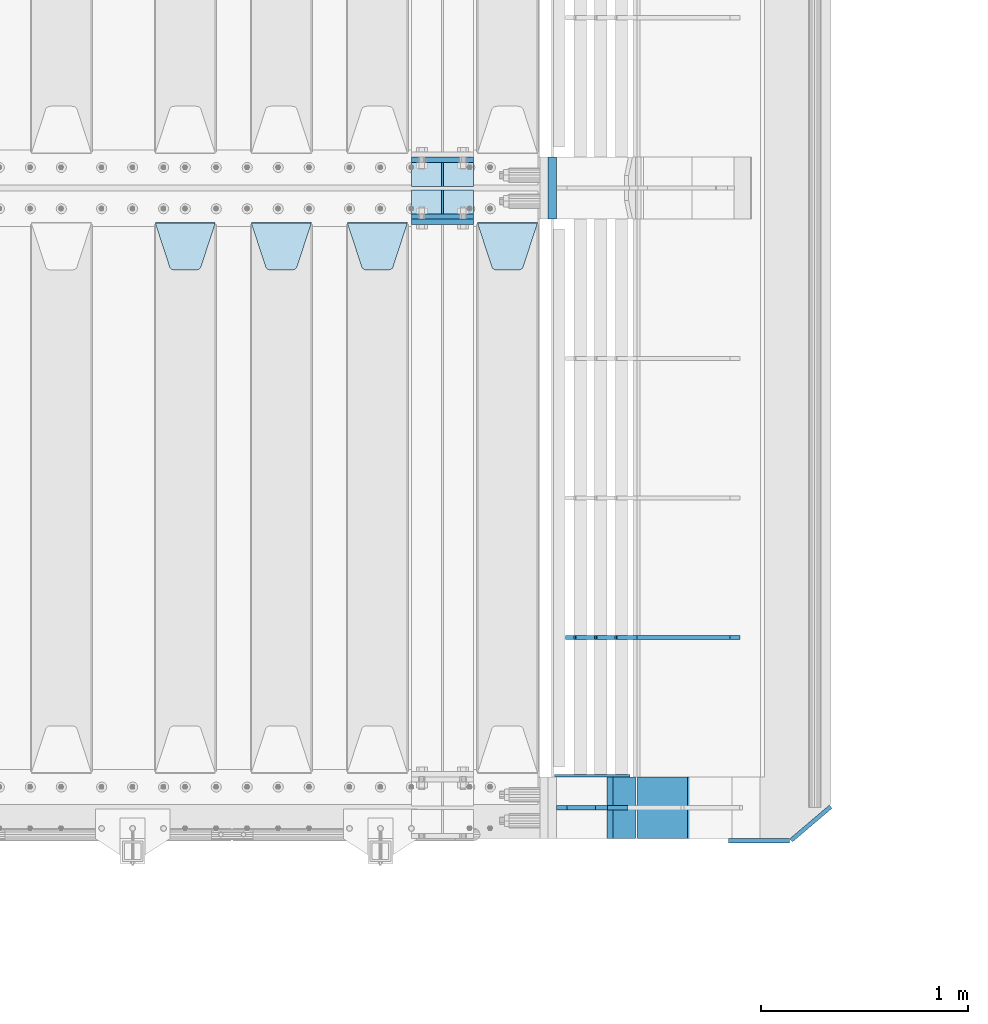
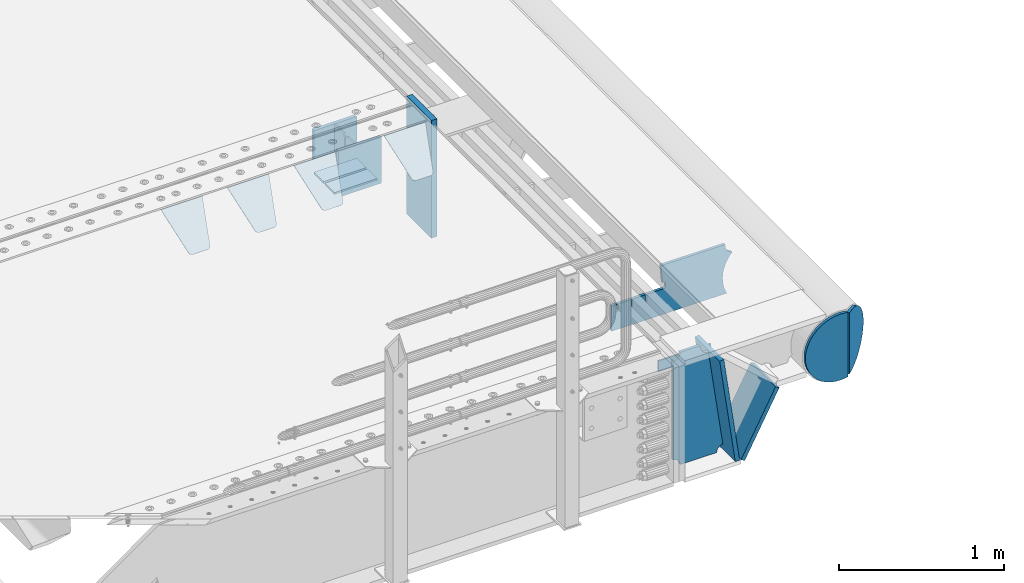
# One storey, part 235 of 257: 19 plates.
"""IFC2X3 building model written with IfcOpenShell, lengths in millimetres."""

from ifc_helpers import new_model, si_unit, frame, origin_with_axes, place, context, subcontext, project, spatial, faceted_brep, material, type_object, element, save


model = new_model("IFC2X3")

# Units and contexts
model_context = context("Model", 3, precision=1e-05, world=origin_with_axes())
body_context = subcontext(model_context, "Body", "Model", "MODEL_VIEW")
ifc_project = project(units=[si_unit("LENGTHUNIT", "METRE", prefix="MILLI"), si_unit("AREAUNIT", "SQUARE_METRE"), si_unit("VOLUMEUNIT", "CUBIC_METRE"), si_unit("MASSUNIT", "GRAM", prefix="KILO"), si_unit("TIMEUNIT", "SECOND"), si_unit("PLANEANGLEUNIT", "RADIAN"), si_unit("SOLIDANGLEUNIT", "STERADIAN"), si_unit("THERMODYNAMICTEMPERATUREUNIT", "DEGREE_CELSIUS"), si_unit("LUMINOUSINTENSITYUNIT", "LUMEN")], contexts=[model_context])

# Site, building, storey
site_placement = place(None, origin_with_axes())
site = spatial("IfcSite", under=ifc_project, at=site_placement, CompositionType="ELEMENT")
building_placement = place(site_placement, origin_with_axes())
building = spatial("IfcBuilding", under=site, at=building_placement, Name="Standard", CompositionType="ELEMENT")
storey_placement = place(building_placement, origin_with_axes())
storey = spatial("IfcBuildingStorey", under=building, at=storey_placement, Name="Undefined", CompositionType="ELEMENT", Elevation=0.0)

# Plates
ifc_material_1 = material(Name="STEEL/S355N")
plate_type_1 = type_object("IfcPlateType", PredefinedType="NOTDEFINED")
for number, where, z_axis, x_axis in (
    (1, (58645.0, 3137.49999999999, -339.999999999993), (0.0, 0.0, 1.0), (1.0, 0.0, 0.0)),
    (2, (58645.0, 2862.49999999999, -339.999999999993), (0.0, 0.0, 1.0), (1.0, 0.0, 0.0)),
):
    element("IfcPlate", number, at=place(storey_placement, frame(where, z_axis=z_axis, x_axis=x_axis)), inside=storey, type_object=plate_type_1, material=ifc_material_1, context=body_context, shape_type="Brep", body=[
        faceted_brep([(0.0, -12.5, 0.0), (0.0, -12.5, 310.0), (0.0, 12.5, 310.0), (0.0, 12.5, 0.0), (300.0, -12.5, 310.0), (300.0, 12.5, 310.0), (300.0, -12.5, 0.0), (300.0, 12.5, 0.0)], [[[0, 1, 2, 3]], [[1, 4, 5, 2]], [[4, 6, 7, 5]], [[6, 0, 3, 7]], [[5, 7, 3, 2]], [[6, 4, 1, 0]]]),
    ])
plate_1_placement = place(storey_placement, frame((58645.0, 2837.5, -340.000000000044), z_axis=(0.0, 0.0, 1.0), x_axis=(1.0, 0.0, 0.0)))
element("IfcPlate", 3, at=plate_1_placement, inside=storey, type_object=plate_type_1, material=ifc_material_1, context=body_context, shape_type="Brep", body=[
    faceted_brep([(0.0, -12.5, 0.0), (0.0, -12.5, 340.0), (0.0, 12.5, 340.0), (0.0, 12.5, 0.0), (300.0, -12.5, 340.0), (300.0, 12.5, 340.0), (300.0, -12.5, 0.0), (300.0, 12.5, 0.0)], [[[0, 1, 2, 3]], [[1, 4, 5, 2]], [[4, 6, 7, 5]], [[6, 0, 3, 7]], [[5, 7, 3, 2]], [[6, 4, 1, 0]]]),
])
plate_type_2 = type_object("IfcPlateType", PredefinedType="NOTDEFINED")
for number, where, z_axis, x_axis in (
    (4, (58645.0, 2991.99999999999, -342.999999999993), (0.0, -1.0, 0.0), (1.0, 0.0, 0.0)),
    (5, (58645.0, 3007.99999999999, -342.999999999993), (0.0, 1.0, 0.0), (1.0, 0.0, 0.0)),
):
    element("IfcPlate", number, at=place(storey_placement, frame(where, z_axis=z_axis, x_axis=x_axis)), inside=storey, type_object=plate_type_2, material=ifc_material_1, context=body_context, shape_type="Brep", body=[
        faceted_brep([(0.0, -7.0, 0.0), (0.0, -7.0, 117.0), (0.0, 7.0, 117.0), (0.0, 7.0, 0.0), (300.0, -7.0, 117.0), (300.0, 7.0, 117.0), (300.0, -7.0, 0.0), (300.0, 7.0, 0.0)], [[[0, 1, 2, 3]], [[1, 4, 5, 2]], [[4, 6, 7, 5]], [[6, 0, 3, 7]], [[5, 7, 3, 2]], [[6, 4, 1, 0]]]),
    ])
plate_type_3 = type_object("IfcPlateType", PredefinedType="NOTDEFINED")
for number, where, z_axis, x_axis in (
    (6, (58795.0, 3007.99999999999, -29.999999999993), (0.0, 0.0, -1.0), (0.0, 1.0, 0.0)),
    (7, (58795.0, 2991.99999999999, -29.999999999993), (0.0, 0.0, -1.0), (0.0, -1.0, 0.0)),
):
    element("IfcPlate", number, at=place(storey_placement, frame(where, z_axis=z_axis, x_axis=x_axis)), inside=storey, type_object=plate_type_3, material=ifc_material_1, context=body_context, shape_type="Brep", body=[
        faceted_brep([(0.0, -5.0, 30.0), (0.0, -5.0, 306.0), (0.0, 5.0, 306.0), (0.0, 5.0, 30.0), (117.0, -5.0, 306.0), (117.0, 5.0, 306.0), (117.0, -5.0, 0.0), (117.0, 5.0, 0.0), (30.0, -5.0, 0.0), (30.0, 5.0, 0.0), (24.7905546699922, -5.0, 0.455767409633758), (24.7905546699922, 5.0, 0.455767409633758), (19.7393957002296, -5.0, 1.80922137642275), (19.7393957002296, 5.0, 1.80922137642275), (15.0, -5.0, 4.01923788646684), (15.0, 5.0, 4.01923788646684), (10.7163717094036, -5.0, 7.01866670643066), (10.7163717094036, 5.0, 7.01866670643066), (7.01866670643085, -5.0, 10.7163717094038), (7.01866670643085, 5.0, 10.7163717094038), (4.01923788646673, -5.0, 15.0), (4.01923788646673, 5.0, 15.0), (1.80922137642301, -5.0, 19.7393957002299), (1.80922137642301, 5.0, 19.7393957002299), (0.455767409634063, -5.0, 24.7905546699921), (0.455767409634063, 5.0, 24.7905546699921)], [[[0, 1, 2, 3]], [[1, 4, 5, 2]], [[4, 6, 7, 5]], [[6, 8, 9, 7]], [[8, 10, 11, 9]], [[10, 12, 13, 11]], [[12, 14, 15, 13]], [[14, 16, 17, 15]], [[16, 18, 19, 17]], [[18, 20, 21, 19]], [[20, 22, 23, 21]], [[22, 24, 25, 23]], [[24, 0, 3, 25]], [[5, 7, 9, 11, 13, 15, 17, 19, 21, 23, 25, 3, 2]], [[24, 22, 20, 18, 16, 14, 12, 10, 8, 6, 4, 1, 0]]]),
    ])
plate_type_4 = type_object("IfcPlateType", PredefinedType="NOTDEFINED")
plate_2_placement = place(storey_placement, frame((58965.0, 2831.76776695594, -1.767766952965), z_axis=(0.0, -0.707106781186548, -0.707106781186547), x_axis=(1.0, 0.0, 0.0)))
element("IfcPlate", 8, at=plate_2_placement, inside=storey, type_object=plate_type_4, material=ifc_material_1, context=body_context, shape_type="Brep", body=[
    faceted_brep([(0.0, -2.5, 0.0), (69.345504679477, -2.50000000000091, 300.17173142483), (69.345504679477, 2.5, 300.171731424831), (0.0, 2.5, 0.0), (70.927406119954, -2.50000000000091, 304.8974424154), (70.927406119954, 2.5, 304.8974424154), (73.3818627772271, -2.50000000000091, 309.234538108527), (73.3818627772271, 2.49999999999909, 309.234538108527), (76.6187032999587, -2.5, 313.023683126103), (76.6187032999587, 2.5, 313.023683126103), (80.5190132705029, -2.5, 316.125672595372), (80.5190132705029, 2.5, 316.125672595371), (84.9395038596849, -2.5, 318.426546230476), (84.9395038596849, 2.5, 318.426546230477), (89.7177759439219, -2.5, 319.841774983275), (89.7177759439219, 2.5, 319.841774983275), (94.6782862926484, -2.5, 320.319366455079), (94.6782862926484, 2.5, 320.319366455079), (195.321713707352, -2.5, 320.319366455079), (195.321713707352, 2.5, 320.319366455079), (200.282224056078, -2.5, 319.841774983275), (200.282224056078, 2.49999999999909, 319.841774983275), (205.060496140315, -2.5, 318.426546230476), (205.060496140315, 2.49999999999909, 318.426546230475), (209.480986729497, -2.5, 316.125672595371), (209.480986729497, 2.5, 316.125672595371), (213.381296700041, -2.50000000000091, 313.023683126102), (213.381296700041, 2.5, 313.023683126103), (216.618137222766, -2.50000000000091, 309.234538108527), (216.618137222766, 2.5, 309.234538108527), (219.072593880039, -2.5, 304.897442415399), (219.072593880039, 2.5, 304.897442415399), (220.654495320523, -2.50000000000091, 300.17173142483), (220.654495320523, 2.5, 300.171731424831), (290.0, -2.50000000000091, 0.0), (290.0, 2.5, 9.09494701772928e-13)], [[[0, 1, 2, 3]], [[1, 4, 5, 2]], [[4, 6, 7, 5]], [[6, 8, 9, 7]], [[8, 10, 11, 9]], [[10, 12, 13, 11]], [[12, 14, 15, 13]], [[14, 16, 17, 15]], [[16, 18, 19, 17]], [[18, 20, 21, 19]], [[20, 22, 23, 21]], [[22, 24, 25, 23]], [[24, 26, 27, 25]], [[26, 28, 29, 27]], [[28, 30, 31, 29]], [[30, 32, 33, 31]], [[32, 34, 35, 33]], [[34, 0, 3, 35]], [[5, 7, 9, 11, 13, 15, 17, 19, 21, 23, 25, 27, 29, 31, 33, 35, 3, 2]], [[34, 32, 30, 28, 26, 24, 22, 20, 18, 16, 14, 12, 10, 8, 6, 4, 1, 0]]]),
])
plate_3_placement = place(storey_placement, frame((58335.0, 2831.76776695594, -1.767766952965), z_axis=(0.0, -0.707106781186548, -0.707106781186547), x_axis=(1.0, 0.0, 0.0)))
element("IfcPlate", 9, at=plate_3_placement, inside=storey, type_object=plate_type_4, material=ifc_material_1, context=body_context, shape_type="Brep", body=[
    faceted_brep([(0.0, -2.5, 0.0), (69.345504679477, -2.50000000000091, 300.17173142483), (69.345504679477, 2.5, 300.171731424831), (0.0, 2.5, 0.0), (70.927406119954, -2.50000000000091, 304.8974424154), (70.927406119954, 2.5, 304.8974424154), (73.3818627772271, -2.50000000000091, 309.234538108527), (73.3818627772271, 2.49999999999909, 309.234538108527), (76.6187032999587, -2.5, 313.023683126103), (76.6187032999587, 2.5, 313.023683126103), (80.5190132705029, -2.5, 316.125672595372), (80.5190132705029, 2.5, 316.125672595371), (84.9395038596849, -2.5, 318.426546230476), (84.9395038596849, 2.5, 318.426546230477), (89.7177759439219, -2.5, 319.841774983275), (89.7177759439219, 2.5, 319.841774983275), (94.6782862926484, -2.5, 320.319366455079), (94.6782862926484, 2.5, 320.319366455079), (195.321713707352, -2.5, 320.319366455079), (195.321713707352, 2.5, 320.319366455079), (200.282224056078, -2.5, 319.841774983275), (200.282224056078, 2.49999999999909, 319.841774983275), (205.060496140315, -2.5, 318.426546230476), (205.060496140315, 2.49999999999909, 318.426546230475), (209.480986729497, -2.5, 316.125672595371), (209.480986729497, 2.5, 316.125672595371), (213.381296700041, -2.50000000000091, 313.023683126102), (213.381296700041, 2.5, 313.023683126103), (216.618137222766, -2.50000000000091, 309.234538108527), (216.618137222766, 2.5, 309.234538108527), (219.072593880039, -2.5, 304.897442415399), (219.072593880039, 2.5, 304.897442415399), (220.654495320523, -2.50000000000091, 300.17173142483), (220.654495320523, 2.5, 300.171731424831), (290.0, -2.50000000000091, 0.0), (290.0, 2.5, 9.09494701772928e-13)], [[[0, 1, 2, 3]], [[1, 4, 5, 2]], [[4, 6, 7, 5]], [[6, 8, 9, 7]], [[8, 10, 11, 9]], [[10, 12, 13, 11]], [[12, 14, 15, 13]], [[14, 16, 17, 15]], [[16, 18, 19, 17]], [[18, 20, 21, 19]], [[20, 22, 23, 21]], [[22, 24, 25, 23]], [[24, 26, 27, 25]], [[26, 28, 29, 27]], [[28, 30, 31, 29]], [[30, 32, 33, 31]], [[32, 34, 35, 33]], [[34, 0, 3, 35]], [[5, 7, 9, 11, 13, 15, 17, 19, 21, 23, 25, 27, 29, 31, 33, 35, 3, 2]], [[34, 32, 30, 28, 26, 24, 22, 20, 18, 16, 14, 12, 10, 8, 6, 4, 1, 0]]]),
])
plate_4_placement = place(storey_placement, frame((57870.0, 2831.76776695594, -1.767766952965), z_axis=(0.0, -0.707106781186548, -0.707106781186547), x_axis=(1.0, 0.0, 0.0)))
element("IfcPlate", 10, at=plate_4_placement, inside=storey, type_object=plate_type_4, material=ifc_material_1, context=body_context, shape_type="Brep", body=[
    faceted_brep([(0.0, -2.5, 0.0), (69.345504679477, -2.50000000000091, 300.17173142483), (69.345504679477, 2.5, 300.171731424831), (0.0, 2.5, 0.0), (70.927406119954, -2.50000000000091, 304.8974424154), (70.927406119954, 2.5, 304.8974424154), (73.3818627772271, -2.50000000000091, 309.234538108527), (73.3818627772271, 2.49999999999909, 309.234538108527), (76.6187032999587, -2.5, 313.023683126103), (76.6187032999587, 2.5, 313.023683126103), (80.5190132705029, -2.5, 316.125672595372), (80.5190132705029, 2.5, 316.125672595371), (84.9395038596849, -2.5, 318.426546230476), (84.9395038596849, 2.5, 318.426546230477), (89.7177759439219, -2.5, 319.841774983275), (89.7177759439219, 2.5, 319.841774983275), (94.6782862926484, -2.5, 320.319366455079), (94.6782862926484, 2.5, 320.319366455079), (195.321713707352, -2.5, 320.319366455079), (195.321713707352, 2.5, 320.319366455079), (200.282224056078, -2.5, 319.841774983275), (200.282224056078, 2.49999999999909, 319.841774983275), (205.060496140315, -2.5, 318.426546230476), (205.060496140315, 2.49999999999909, 318.426546230475), (209.480986729497, -2.5, 316.125672595371), (209.480986729497, 2.5, 316.125672595371), (213.381296700041, -2.50000000000091, 313.023683126102), (213.381296700041, 2.5, 313.023683126103), (216.618137222766, -2.50000000000091, 309.234538108527), (216.618137222766, 2.5, 309.234538108527), (219.072593880039, -2.5, 304.897442415399), (219.072593880039, 2.5, 304.897442415399), (220.654495320523, -2.50000000000091, 300.17173142483), (220.654495320523, 2.5, 300.171731424831), (290.0, -2.50000000000091, 0.0), (290.0, 2.5, 9.09494701772928e-13)], [[[0, 1, 2, 3]], [[1, 4, 5, 2]], [[4, 6, 7, 5]], [[6, 8, 9, 7]], [[8, 10, 11, 9]], [[10, 12, 13, 11]], [[12, 14, 15, 13]], [[14, 16, 17, 15]], [[16, 18, 19, 17]], [[18, 20, 21, 19]], [[20, 22, 23, 21]], [[22, 24, 25, 23]], [[24, 26, 27, 25]], [[26, 28, 29, 27]], [[28, 30, 31, 29]], [[30, 32, 33, 31]], [[32, 34, 35, 33]], [[34, 0, 3, 35]], [[5, 7, 9, 11, 13, 15, 17, 19, 21, 23, 25, 27, 29, 31, 33, 35, 3, 2]], [[34, 32, 30, 28, 26, 24, 22, 20, 18, 16, 14, 12, 10, 8, 6, 4, 1, 0]]]),
])
plate_5_placement = place(storey_placement, frame((57405.0, 2831.76776695594, -1.767766952965), z_axis=(0.0, -0.707106781186548, -0.707106781186547), x_axis=(1.0, 0.0, 0.0)))
element("IfcPlate", 11, at=plate_5_placement, inside=storey, type_object=plate_type_4, material=ifc_material_1, context=body_context, shape_type="Brep", body=[
    faceted_brep([(0.0, -2.5, 0.0), (69.345504679477, -2.50000000000091, 300.17173142483), (69.345504679477, 2.5, 300.171731424831), (0.0, 2.5, 0.0), (70.927406119954, -2.50000000000091, 304.8974424154), (70.927406119954, 2.5, 304.8974424154), (73.3818627772271, -2.50000000000091, 309.234538108527), (73.3818627772271, 2.49999999999909, 309.234538108527), (76.6187032999587, -2.5, 313.023683126103), (76.6187032999587, 2.5, 313.023683126103), (80.5190132705029, -2.5, 316.125672595372), (80.5190132705029, 2.5, 316.125672595371), (84.9395038596849, -2.5, 318.426546230476), (84.9395038596849, 2.5, 318.426546230477), (89.7177759439219, -2.5, 319.841774983275), (89.7177759439219, 2.5, 319.841774983275), (94.6782862926484, -2.5, 320.319366455079), (94.6782862926484, 2.5, 320.319366455079), (195.321713707352, -2.5, 320.319366455079), (195.321713707352, 2.5, 320.319366455079), (200.282224056078, -2.5, 319.841774983275), (200.282224056078, 2.49999999999909, 319.841774983275), (205.060496140315, -2.5, 318.426546230476), (205.060496140315, 2.49999999999909, 318.426546230475), (209.480986729497, -2.5, 316.125672595371), (209.480986729497, 2.5, 316.125672595371), (213.381296700041, -2.50000000000091, 313.023683126102), (213.381296700041, 2.5, 313.023683126103), (216.618137222766, -2.50000000000091, 309.234538108527), (216.618137222766, 2.5, 309.234538108527), (219.072593880039, -2.5, 304.897442415399), (219.072593880039, 2.5, 304.897442415399), (220.654495320523, -2.50000000000091, 300.17173142483), (220.654495320523, 2.5, 300.171731424831), (290.0, -2.50000000000091, 0.0), (290.0, 2.5, 9.09494701772928e-13)], [[[0, 1, 2, 3]], [[1, 4, 5, 2]], [[4, 6, 7, 5]], [[6, 8, 9, 7]], [[8, 10, 11, 9]], [[10, 12, 13, 11]], [[12, 14, 15, 13]], [[14, 16, 17, 15]], [[16, 18, 19, 17]], [[18, 20, 21, 19]], [[20, 22, 23, 21]], [[22, 24, 25, 23]], [[24, 26, 27, 25]], [[26, 28, 29, 27]], [[28, 30, 31, 29]], [[30, 32, 33, 31]], [[32, 34, 35, 33]], [[34, 0, 3, 35]], [[5, 7, 9, 11, 13, 15, 17, 19, 21, 23, 25, 27, 29, 31, 33, 35, 3, 2]], [[34, 32, 30, 28, 26, 24, 22, 20, 18, 16, 14, 12, 10, 8, 6, 4, 1, 0]]]),
])
ifc_material_2 = material()
plate_type_5 = type_object("IfcPlateType", PredefinedType="NOTDEFINED")
plate_6_placement = place(storey_placement, frame((59326.9988298908, 3150.0, -889.999999999995), z_axis=(0.0, 0.0, 1.0), x_axis=(0.0, -1.0, 0.0)))
element("IfcPlate", 12, at=plate_6_placement, inside=storey, type_object=plate_type_5, material=ifc_material_2, context=body_context, shape_type="Brep", body=[
    faceted_brep([(0.0, -20.0, 0.0), (0.0, -20.0, 870.0), (0.0, 20.0, 870.0), (0.0, 20.0, 0.0), (300.0, -20.0, 870.0), (300.0, 20.0, 870.0), (300.0, -20.0, -1.81898940354586e-12), (300.0, 20.0, -1.81898940354586e-12)], [[[0, 1, 2, 3]], [[1, 4, 5, 2]], [[4, 6, 7, 5]], [[6, 0, 3, 7]], [[5, 7, 3, 2]], [[6, 4, 1, 0]]]),
])
plate_type_6 = type_object("IfcPlateType", PredefinedType="NOTDEFINED")
plate_7_placement = place(storey_placement, frame((60232.9182339676, 824.999282836914, -374.002067436518), z_axis=(0.0, 0.0, 1.0), x_axis=(-1.0, 0.0, 0.0)))
element("IfcPlate", 13, at=plate_7_placement, inside=storey, type_object=plate_type_6, material=ifc_material_1, context=body_context, shape_type="Brep", body=[
    faceted_brep([(801.919404066546, -10.0, 188.0), (801.919404066546, 10.0, 188.0), (801.919404066546, 10.0, 132.002067436952), (801.919404066546, -10.0, 132.002067436952), (793.919404066546, 10.0, 132.002067436952), (793.919404066546, -10.0, 132.002067436952), (793.919404066546, 10.0, 180.002067436952), (793.919404066546, -10.0, 180.002067436952), (793.52785619691, 10.0, 182.474203391951), (793.52785619691, -10.0, 182.474203391951), (792.391540021548, 10.0, 184.704349455291), (792.391540021548, -10.0, 184.704349455291), (790.621686084887, 10.0, 186.474203391951), (790.621686084887, -10.0, 186.474203391951), (788.391540021548, 10.0, 187.610519567313), (788.391540021548, -10.0, 187.610519567313), (785.919404066546, -10.0, 188.002067436952), (785.919404066546, 10.0, 188.0), (841.0, -10.0, 188.0), (841.0, -10.0, 0.0), (841.0, 10.0, 0.0), (841.0, 10.0, 188.0), (33.3619566735943, -10.0, 0.0), (33.3619566735943, 10.0, 0.0), (36.2350612208102, -10.0, 4.68848050267013), (36.2350612208102, 10.0, 4.68848050267013), (51.4877592159319, -10.0, 41.5117508652784), (51.4877592159319, 10.0, 41.5117508652784), (60.7922425881334, -10.0, 80.2677133162964), (60.7922425881334, 10.0, 80.2677133162964), (63.9194040769653, -10.0, 120.002067436515), (63.9194040769653, 10.0, 120.002067436515), (60.7922425881334, -10.0, 159.736421556734), (60.7922425881334, 10.0, 159.736421556734), (51.4877592159319, -10.0, 198.492384007752), (51.4877592159319, 10.0, 198.492384007752), (36.2350612208102, -10.0, 235.31565437036), (36.2350612208102, 10.0, 235.31565437036), (15.4097206482038, -10.0, 269.299521518803), (15.4097206482038, 10.0, 269.299521518803), (-3.35474438100209, -10.0, 291.269887256574), (-3.35474438100209, 10.0, 291.269887256574), (-2.36881039375294, -10.0000000000001, 291.426043859339), (-2.36881039375294, 10.0, 291.426043859339), (17.1449676604752, -10.0000000000001, 301.368810393754), (17.1449676604752, 10.0, 301.368810393754), (32.6311896062471, -10.0000000000001, 316.855032339527), (32.6311896062471, 10.0, 316.855032339527), (42.573956140659, -10.0000000000001, 336.368810393754), (42.573956140659, 10.0, 336.368810393754), (46.0, -10.0000000000001, 358.0), (46.0, 10.0, 358.0), (45.0495205499174, -10.0, 364.001091067617), (45.0495205499174, 10.0, 364.001091067617), (495.040008544922, -10.0, 364.010009765625), (495.040008544922, 10.0, 364.010009765625), (483.600036621094, -10.0, 233.759994506836), (483.600036621094, 10.0, 233.759994506836), (472.0, -10.0, 233.759994506836), (472.0, 10.0, 233.759994506836), (468.909830056247, -10.0, 233.270559669787), (468.909830056247, 10.0, 233.270559669787), (466.122147477072, -10.0, 231.850164450585), (466.122147477072, 10.0, 231.850164450585), (463.909830056247, -10.0, 229.637847029761), (463.909830056247, 10.0, 229.637847029761), (462.489434837051, -10.0, 226.850164450585), (462.489434837051, 10.0, 226.850164450585), (462.0, -10.0, 223.759994506836), (462.0, 10.0, 223.759994506836), (462.0, -10.0, 198.0), (462.0, 10.0, 198.0), (462.489434837051, -10.0, 194.909830056251), (462.489434837051, 10.0, 194.909830056251), (463.909830056247, -10.0, 192.122147477075), (463.909830056247, 10.0, 192.122147477075), (466.122147477072, -10.0, 189.909830056251), (466.122147477072, 10.0, 189.909830056251), (468.909830056247, -10.0, 188.489434837048), (468.909830056247, 10.0, 188.489434837048), (472.0, -10.0, 188.0), (472.0, 10.0, 188.0), (585.919404066546, -10.0, 188.002067436952), (585.919404066546, 10.0, 188.0), (588.391540021548, -10.0, 187.610519567313), (588.391540021548, 10.0, 187.610519567313), (590.621686084887, -10.0, 186.474203391951), (590.621686084887, 10.0, 186.474203391951), (592.391540021548, -10.0, 184.704349455291), (592.391540021548, 10.0, 184.704349455291), (593.52785619691, -10.0, 182.474203391951), (593.52785619691, 10.0, 182.474203391951), (593.919404066546, -10.0, 180.002067436952), (593.919404066546, 10.0, 180.002067436952), (593.919404066546, -10.0, 132.002067436952), (593.919404066546, 10.0, 132.002067436952), (601.919404066546, -10.0, 132.002067436952), (601.919404066546, 10.0, 132.002067436952), (601.919404066546, -10.0, 188.0), (601.919404066546, 10.0, 188.0), (685.919404066546, -10.0, 188.002067436952), (685.919404066546, 10.0, 188.0), (688.391540021548, -9.99999999999977, 187.610519567313), (688.391540021548, 10.0, 187.610519567313), (690.621686084887, -9.99999999999977, 186.474203391951), (690.621686084887, 10.0, 186.474203391951), (692.391540021548, -9.99999999999977, 184.704349455291), (692.391540021548, 10.0, 184.704349455291), (693.52785619691, -9.99999999999977, 182.474203391951), (693.52785619691, 10.0, 182.474203391951), (693.919404066546, -9.99999999999977, 180.002067436952), (693.919404066546, 10.0, 180.002067436952), (693.919404066546, -9.99999999999977, 132.002067436952), (693.919404066546, 10.0, 132.002067436952), (701.919404066546, -9.99999999999977, 132.002067436952), (701.919404066546, 10.0, 132.002067436952), (701.919404066546, -10.0, 188.0), (701.919404066546, 10.0, 188.0)], [[[0, 1, 2, 3]], [[3, 2, 4, 5]], [[5, 4, 6, 7]], [[7, 6, 8, 9]], [[9, 8, 10, 11]], [[11, 10, 12, 13]], [[13, 12, 14, 15]], [[16, 15, 14, 17]], [[18, 19, 20, 21]], [[20, 19, 22, 23]], [[22, 24, 25, 23]], [[26, 27, 25, 24]], [[28, 29, 27, 26]], [[30, 31, 29, 28]], [[32, 33, 31, 30]], [[34, 35, 33, 32]], [[36, 37, 35, 34]], [[38, 39, 37, 36]], [[39, 38, 40, 41]], [[40, 42, 43, 41]], [[44, 45, 43, 42]], [[46, 47, 45, 44]], [[48, 49, 47, 46]], [[50, 51, 49, 48]], [[52, 53, 51, 50]], [[54, 55, 53, 52]], [[54, 56, 57, 55]], [[56, 58, 59, 57]], [[58, 60, 61, 59]], [[60, 62, 63, 61]], [[62, 64, 65, 63]], [[64, 66, 67, 65]], [[66, 68, 69, 67]], [[68, 70, 71, 69]], [[70, 72, 73, 71]], [[72, 74, 75, 73]], [[74, 76, 77, 75]], [[76, 78, 79, 77]], [[78, 80, 81, 79]], [[81, 80, 82, 83]], [[82, 84, 85, 83]], [[86, 87, 85, 84]], [[88, 89, 87, 86]], [[90, 91, 89, 88]], [[92, 93, 91, 90]], [[94, 95, 93, 92]], [[96, 97, 95, 94]], [[98, 99, 97, 96]], [[99, 98, 100, 101]], [[100, 102, 103, 101]], [[104, 105, 103, 102]], [[106, 107, 105, 104]], [[108, 109, 107, 106]], [[110, 111, 109, 108]], [[112, 113, 111, 110]], [[114, 115, 113, 112]], [[116, 117, 115, 114]], [[117, 116, 16, 17]], [[12, 10, 8, 6, 4, 2, 1, 21, 20, 23, 25, 27, 29, 31, 33, 35, 37, 39, 41, 43, 45, 47, 49, 51, 53, 55, 57, 59, 61, 63, 65, 67, 69, 71, 73, 75, 77, 79, 81, 83, 85, 87, 89, 91, 93, 95, 97, 99, 101, 103, 105, 107, 109, 111, 113, 115, 117, 17, 14]], [[18, 21, 1, 0]], [[116, 114, 112, 110, 108, 106, 104, 102, 100, 98, 96, 94, 92, 90, 88, 86, 84, 82, 80, 78, 76, 74, 72, 70, 68, 66, 64, 62, 60, 58, 56, 54, 52, 50, 48, 46, 44, 42, 40, 38, 36, 34, 32, 30, 28, 26, 24, 22, 19, 18, 0, 3, 5, 7, 9, 11, 13, 15, 16]]]),
])
plate_type_7 = type_object("IfcPlateType", PredefinedType="NOTDEFINED")
plate_8_placement = place(storey_placement, frame((59716.1480677228, 150.000000001004, -862.083788726708), z_axis=(-0.139173011053008, 0.0, 0.990268081377179), x_axis=(0.0, -1.0, 0.0)))
element("IfcPlate", 14, at=plate_8_placement, inside=storey, type_object=plate_type_7, material=ifc_material_1, context=body_context, shape_type="Brep", body=[
    faceted_brep([(1.00411057246674e-09, 14.9994702460463, -0.00376939772104379), (300.0, 15.0, 0.0), (300.0, -15.0, 4.21237841382026), (0.0, -15.0, 4.21237841382026), (0.0, -15.0000000000073, 792.000000000002), (300.0, -15.0000000000073, 792.000000000002), (300.0, 14.9999999999927, 792.000000000002), (0.0, 14.9999999999927, 792.000000000002)], [[[0, 1, 2, 3]], [[4, 5, 6, 7]], [[4, 7, 0, 3]], [[5, 4, 3, 2]], [[6, 5, 2, 1]], [[7, 6, 1, 0]]]),
])
plate_9_placement = place(storey_placement, frame((59753.2468009574, 150.000000001004, -867.038754737463), z_axis=(0.469471552246179, 0.0, 0.882947598462991), x_axis=(0.0, -1.0, 0.0)))
element("IfcPlate", 15, at=plate_9_placement, inside=storey, type_object=plate_type_7, material=ifc_material_1, context=body_context, shape_type="Brep", body=[
    faceted_brep([(0.0, -15.0, 0.0), (0.0, -15.0, 514.999999999996), (0.0, 15.0, 515.0), (0.0, 15.0, 0.0), (300.0, -15.0, 514.999999999996), (300.0, 15.0, 515.0), (300.0, -15.0, 0.0), (300.0, 15.0, 0.0)], [[[0, 1, 2, 3]], [[1, 4, 5, 2]], [[4, 6, 7, 5]], [[6, 0, 3, 7]], [[5, 7, 3, 2]], [[6, 4, 1, 0]]]),
])
plate_type_8 = type_object("IfcPlateType", PredefinedType="NOTDEFINED")
plate_10_placement = place(storey_placement, frame((59585.9988298891, 0.0, -30.0000000026171), z_axis=(0.0, 0.0, -1.0), x_axis=(-1.0, 0.0, 0.0)))
element("IfcPlate", 16, at=plate_10_placement, inside=storey, type_object=plate_type_8, material=ifc_material_1, context=body_context, shape_type="Brep", body=[
    faceted_brep([(-9.00602409638668, -10.0, 65.0), (-108.137843376921, -10.0, 780.473130459514), (-108.137843376921, 10.0, 780.473130459514), (-9.00602409638668, 10.0, 65.0), (-94.4157884488377, -10.0, 784.433672138112), (-94.4157884488377, 10.0, 784.433672138112), (-82.3732461236723, -10.0, 792.112074067144), (-82.3732461236723, 10.0, 792.112074067144), (-72.9927947992401, -10.0, 802.881837982249), (-72.9927947992401, 10.0, 802.881837982249), (-67.0398068183713, -10.0, 815.864234368775), (-67.0398068183713, 10.0, 815.864234368775), (-65.0, -10.0, 830.0), (-65.0, 10.0, 830.0), (189.0, -10.0, 830.0), (189.0, 10.0, 830.0), (191.447174185239, -10.0, 814.549150281253), (191.447174185239, 10.0, 814.549150281253), (198.549150281251, -10.0, 800.610737385376), (198.549150281251, 10.0, 800.610737385376), (209.610737385374, -10.0, 789.549150281253), (209.610737385374, 10.0, 789.549150281253), (223.549150281251, -10.0, 782.447174185242), (223.549150281251, 10.0, 782.447174185242), (239.0, -10.0, 780.0), (239.0, 10.0, 780.0), (239.0, -10.0, 50.0), (239.0, 10.0, 50.0), (223.549150281251, -10.0, 47.5528258147577), (223.549150281251, 10.0, 47.5528258147577), (209.610737385374, -10.0, 40.4508497187474), (209.610737385374, 10.0, 40.4508497187474), (198.549150281251, -10.0, 29.3892626146237), (198.549150281251, 10.0, 29.3892626146237), (191.447174185239, -10.0, 15.4508497187474), (191.447174185239, 10.0, 15.4508497187474), (189.0, -10.0, 0.0), (189.0, 10.0, 0.0), (50.4776502774184, -10.0, 0.0), (50.4776502774184, 10.0, 0.0), (47.3830020671812, -10.0, 22.3352870825933), (47.3830020671812, 10.0, 22.3352870825933), (42.8384615202813, -10.0, 37.3040735979326), (42.8384615202813, 10.0, 37.3040735979326), (33.8907372011745, -10.0, 50.1358952937587), (33.8907372011745, 10.0, 50.1358952937587), (21.415694708674, -10.0, 59.5746840579253), (21.415694708674, 10.0, 59.5746840579253), (6.63447812067898, -10.0, 64.6965054822873), (6.63447812067898, 10.0, 64.6965054822873)], [[[0, 1, 2, 3]], [[1, 4, 5, 2]], [[4, 6, 7, 5]], [[6, 8, 9, 7]], [[8, 10, 11, 9]], [[10, 12, 13, 11]], [[12, 14, 15, 13]], [[14, 16, 17, 15]], [[16, 18, 19, 17]], [[18, 20, 21, 19]], [[20, 22, 23, 21]], [[22, 24, 25, 23]], [[24, 26, 27, 25]], [[26, 28, 29, 27]], [[28, 30, 31, 29]], [[30, 32, 33, 31]], [[32, 34, 35, 33]], [[34, 36, 37, 35]], [[36, 38, 39, 37]], [[38, 40, 41, 39]], [[40, 42, 43, 41]], [[42, 44, 45, 43]], [[44, 46, 47, 45]], [[46, 48, 49, 47]], [[48, 0, 3, 49]], [[5, 7, 9, 11, 13, 15, 17, 19, 21, 23, 25, 27, 29, 31, 33, 35, 37, 39, 41, 43, 45, 47, 49, 3, 2]], [[48, 46, 44, 42, 40, 38, 36, 34, 32, 30, 28, 26, 24, 22, 20, 18, 16, 14, 12, 10, 8, 6, 4, 1, 0]]]),
])
plate_type_9 = type_object("IfcPlateType", PredefinedType="NOTDEFINED")
plate_11_placement = place(storey_placement, frame((60667.0025260065, -160.0, -498.0), z_axis=(0.0, 0.0, 1.0), x_axis=(-1.0, 0.0, 0.0)))
element("IfcPlate", 17, at=plate_11_placement, inside=storey, type_object=plate_type_9, material=ifc_material_1, context=body_context, shape_type="Brep", body=[
    faceted_brep([(244.0, -10.0, 0.0), (209.275179461321, -10.0, 2.48356818105242), (209.275179461321, 10.0, 2.48356818105242), (244.0, 10.0, 0.0), (278.724820538679, -10.0, 2.48356818105236), (278.724820538679, 10.0, 2.48356818105236), (312.742743869312, -10.0, 9.88371443806261), (312.742743869312, 10.0, 9.88371443806261), (345.361263172461, -10.0, 22.0497931334975), (345.361263172461, 10.0, 22.0497931334975), (375.916359459166, -10.0, 38.7341379891918), (375.916359459166, 10.0, 38.7341379891918), (403.786019082647, -10.0, 59.597103857561), (403.786019082647, 10.0, 59.597103857561), (428.402896142441, -10.0, 84.2139809173505), (428.402896142441, 10.0, 84.2139809173505), (449.265862010805, -10.0, 112.083640540834), (449.265862010805, 10.0, 112.083640540834), (465.950206866502, -10.0, 142.63873682754), (465.950206866502, 10.0, 142.63873682754), (478.11628556194, -10.0, 175.257256130691), (478.11628556194, 10.0, 175.257256130691), (485.516431818949, -10.0, 209.275179461318), (485.516431818949, 10.0, 209.275179461318), (488.0, -10.0, 244.0), (488.0, 10.0, 244.0), (485.516431818949, -10.0, 278.724820538682), (485.516431818949, 10.0, 278.724820538682), (478.11628556194, -10.0, 312.742743869309), (478.11628556194, 10.0, 312.742743869309), (465.950206866502, -10.0, 345.36126317246), (465.950206866502, 10.0, 345.36126317246), (449.265862010805, -10.0, 375.916359459166), (449.265862010805, 10.0, 375.916359459166), (428.402896142441, -10.0, 403.78601908265), (428.402896142441, 10.0, 403.78601908265), (403.786019082647, -10.0, 428.402896142439), (403.786019082647, 10.0, 428.402896142439), (375.916359459166, -10.0, 449.265862010808), (375.916359459166, 10.0, 449.265862010808), (345.361263172461, -10.0, 465.950206866503), (345.361263172461, 10.0, 465.950206866503), (312.742743869312, -10.0, 478.116285561937), (312.742743869312, 10.0, 478.116285561937), (278.724820538679, -10.0, 485.516431818948), (278.724820538679, 10.0, 485.516431818948), (244.0, -10.0, 488.0), (244.0, 10.0, 488.0), (209.275179461321, -10.0, 485.516431818948), (209.275179461321, 10.0, 485.516431818948), (190.737060236148, -10.0, 481.483710824699), (190.740195025632, -10.0, 6.51560724358956), (190.744745032287, 10.0, 6.51461745022698), (190.741610229736, 10.0, 481.48470061522)], [[[0, 1, 2, 3]], [[4, 0, 3, 5]], [[6, 4, 5, 7]], [[8, 6, 7, 9]], [[10, 8, 9, 11]], [[12, 10, 11, 13]], [[14, 12, 13, 15]], [[16, 14, 15, 17]], [[18, 16, 17, 19]], [[20, 18, 19, 21]], [[22, 20, 21, 23]], [[24, 22, 23, 25]], [[26, 24, 25, 27]], [[28, 26, 27, 29]], [[30, 28, 29, 31]], [[32, 30, 31, 33]], [[34, 32, 33, 35]], [[36, 34, 35, 37]], [[38, 36, 37, 39]], [[40, 38, 39, 41]], [[42, 40, 41, 43]], [[44, 42, 43, 45]], [[46, 44, 45, 47]], [[48, 46, 47, 49]], [[1, 0, 4, 6, 8, 10, 12, 14, 16, 18, 20, 22, 24, 26, 28, 30, 32, 34, 36, 38, 40, 42, 44, 46, 48, 50, 51]], [[2, 1, 51, 52]], [[49, 47, 45, 43, 41, 39, 37, 35, 33, 31, 29, 27, 25, 23, 21, 19, 17, 15, 13, 11, 9, 7, 5, 3, 2, 52, 53]], [[48, 49, 53, 50]], [[52, 51, 50, 53]]]),
])
plate_type_10 = type_object("IfcPlateType", PredefinedType="NOTDEFINED")
plate_12_placement = place(storey_placement, frame((59701.998829901, 155.0, -249.999999999564), z_axis=(-1.0, 0.0, 0.0), x_axis=(0.0, 0.0, 1.0)))
element("IfcPlate", 18, at=plate_12_placement, inside=storey, type_object=plate_type_10, material=ifc_material_1, context=body_context, shape_type="Brep", body=[
    faceted_brep([(0.0, -5.0, 0.0), (0.0, -5.0, 365.0), (0.0, 5.0, 365.0), (0.0, 5.0, 0.0), (80.0, -5.0, 365.0), (80.0, 5.0, 365.0), (80.0, -5.0, 0.0), (80.0, 5.0, 0.0)], [[[0, 1, 2, 3]], [[1, 4, 5, 2]], [[4, 6, 7, 5]], [[6, 0, 3, 7]], [[5, 7, 3, 2]], [[6, 4, 1, 0]]]),
])
plate_type_11 = type_object("IfcPlateType", PredefinedType="NOTDEFINED")
plate_13_placement = place(storey_placement, frame((60520.6718555584, -125.949252021748, -30.6102094248533), z_axis=(-0.0672019719786445, -0.0573522349817724, -0.996089662683424), x_axis=(-0.758955821791683, -0.645120691822885, 0.0883479119757445)))
element("IfcPlate", 19, at=plate_13_placement, inside=storey, type_object=plate_type_11, material=ifc_material_1, context=body_context, shape_type="Brep", body=[
    faceted_brep([(0.0, -10.0, 0.0), (-48.0487670858565, -10.0, 8.67017459869339), (-48.0487670858638, 9.99999999999272, 8.67017459869385), (0.0, 10.0, 0.0), (-93.1337432743094, -10.0000000000073, 25.6771259307857), (-93.1337432743167, 10.0, 25.6771259307857), (-133.522872901609, -10.0, 50.3669013977046), (-133.522872901609, 10.0, 50.3669013977051), (-167.659332237716, -10.0, 81.7918701171875), (-167.659332237723, 10.0, 81.791870117187), (-194.133926336908, -10.0, 118.752426147461), (-194.133926336908, 9.99999999999272, 118.75242614746), (-212.244949267224, -10.0000000000073, 159.800018310547), (-212.244949267217, 10.0, 159.800018310547), (-220.97106924226, -10.0000000000073, 203.387054443359), (-220.97106924226, 10.0, 203.387054443359), (-220.085037117293, -10.0000000000073, 247.827590942382), (-220.0850371173, 10.0, 247.827590942382), (-209.498046740773, -10.0, 291.42578125), (-209.498046740773, 10.0, 291.42578125), (-189.988174285347, -10.0000000000073, 332.472595214844), (-189.988174285339, 10.0, 332.472595214844), (-161.944824048602, -10.0000000000073, 369.423095703125), (-161.944824048602, 10.0, 369.423095703125), (-126.544044310001, -10.0000000000073, 400.847961425781), (-126.544044310001, 10.0, 400.847961425781), (-85.1656568474573, -10.0, 425.538177490234), (-85.16565684745, 10.0, 425.538177490234), (-39.3994558203412, -10.0, 442.545501708984), (-39.3994558203412, 9.99999999999272, 442.545501708984), (8.98411771576502, -10.0, 451.214172363281), (8.98411771576502, 9.99999999999272, 451.214172363281), (49.1690940856861, -10.0, 1.30512489704415e-10), (49.1690940856861, 10.0, 1.30512489704415e-10)], [[[0, 1, 2, 3]], [[1, 4, 5, 2]], [[4, 6, 7, 5]], [[6, 8, 9, 7]], [[8, 10, 11, 9]], [[10, 12, 13, 11]], [[12, 14, 15, 13]], [[14, 16, 17, 15]], [[16, 18, 19, 17]], [[18, 20, 21, 19]], [[20, 22, 23, 21]], [[22, 24, 25, 23]], [[24, 26, 27, 25]], [[26, 28, 29, 27]], [[28, 30, 31, 29]], [[30, 32, 33, 31]], [[32, 0, 3, 33]], [[5, 7, 9, 11, 13, 15, 17, 19, 21, 23, 25, 27, 29, 31, 33, 3, 2]], [[32, 30, 28, 26, 24, 22, 20, 18, 16, 14, 12, 10, 8, 6, 4, 1, 0]]]),
])

save(model, "model.ifc")
